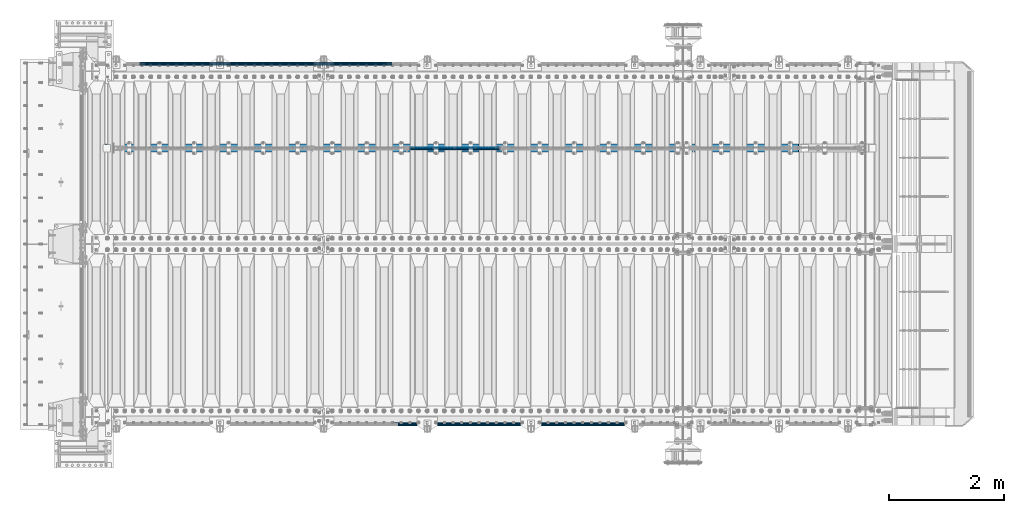
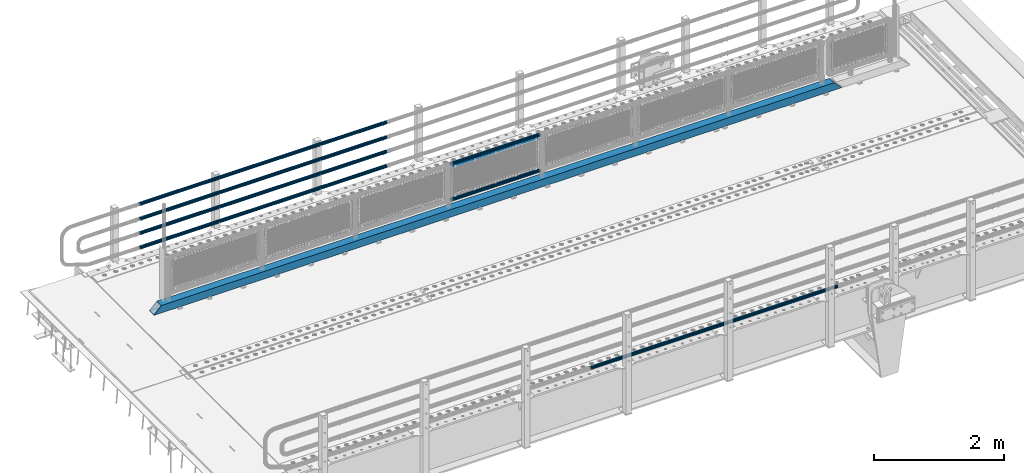
# One storey, part 92 of 193: 9 beams.
"""IFC2X3 building model written with IfcOpenShell, lengths in millimetres."""

from ifc_helpers import new_model, si_unit, frame, origin_with_axes, place, context, subcontext, project, spatial, faceted_brep, material, type_object, element, save


model = new_model("IFC2X3")

# Units and contexts
model_context = context("Model", 3, precision=1e-05, world=origin_with_axes())
body_context = subcontext(model_context, "Body", "Model", "MODEL_VIEW")
ifc_project = project(units=[si_unit("LENGTHUNIT", "METRE", prefix="MILLI"), si_unit("AREAUNIT", "SQUARE_METRE"), si_unit("VOLUMEUNIT", "CUBIC_METRE"), si_unit("MASSUNIT", "GRAM", prefix="KILO"), si_unit("TIMEUNIT", "SECOND"), si_unit("PLANEANGLEUNIT", "RADIAN"), si_unit("SOLIDANGLEUNIT", "STERADIAN"), si_unit("THERMODYNAMICTEMPERATUREUNIT", "DEGREE_CELSIUS"), si_unit("LUMINOUSINTENSITYUNIT", "LUMEN")], contexts=[model_context])

# Site, building, storey
site_placement = place(None, origin_with_axes())
site = spatial("IfcSite", under=ifc_project, at=site_placement, CompositionType="ELEMENT")
building_placement = place(site_placement, origin_with_axes())
building = spatial("IfcBuilding", under=site, at=building_placement, Name="Standard", CompositionType="ELEMENT")
storey_placement = place(building_placement, origin_with_axes())
storey = spatial("IfcBuildingStorey", under=building, at=storey_placement, Name="Undefined", CompositionType="ELEMENT", Elevation=0.0)

# Beams
ifc_material_1 = material()
beam_type_1 = type_object("IfcBeamType", PredefinedType="NOTDEFINED")
beam_1_placement = place(storey_placement, frame((-37116.0000000001, 30129.8500000001, 149.849999999748), z_axis=(0.0, 0.0, -1.0), x_axis=(-1.0, 0.0, 0.0)))
element("IfcBeam", 1, at=beam_1_placement, inside=storey, type_object=beam_type_1, material=ifc_material_1, context=body_context, shape_type="Brep", body=[
    faceted_brep([(0.0, -26.5499999999993, 0.0), (0.0, -24.5290015881765, 10.1602451292931), (4384.00249699992, -24.5290015881765, 10.1602451292931), (4384.00249699992, -26.5499999999993, 0.0), (0.0, -18.7736850405017, 18.7736850405028), (4384.00249699992, -18.7736850405017, 18.7736850405028), (0.0, -10.1602451292929, 24.5290015881747), (4384.00249699992, -10.1602451292929, 24.5290015881747), (0.0, 0.0, 26.55), (4384.00249699992, 0.0, 26.55), (0.0, 10.1602451292929, 24.5290015881747), (4384.00249699992, 10.1602451292929, 24.5290015881747), (0.0, 18.7736850405017, 18.7736850405028), (4384.00249699992, 18.7736850405017, 18.7736850405028), (0.0, 24.5290015881765, 10.1602451292931), (4384.00249699992, 24.5290015881765, 10.1602451292931), (0.0, 26.5499999999993, 0.0), (4384.00249699992, 26.5499999999993, 0.0), (0.0, 24.5290015881765, -10.1602451292931), (4384.00249699992, 24.5290015881765, -10.1602451292931), (0.0, 18.7736850405017, -18.7736850405028), (4384.00249699992, 18.7736850405017, -18.7736850405028), (0.0, 10.1602451292929, -24.5290015881747), (4384.00249699992, 10.1602451292929, -24.5290015881747), (0.0, 0.0, -26.55), (4384.00249699992, 0.0, -26.55), (0.0, -10.1602451292929, -24.5290015881747), (4384.00249699992, -10.1602451292929, -24.5290015881747), (0.0, -18.7736850405017, -18.7736850405028), (4384.00249699992, -18.7736850405017, -18.7736850405028), (0.0, -24.5290015881765, -10.1602451292931), (4384.00249699992, -24.5290015881765, -10.1602451292931), (0.0, -30.1500000000015, 0.0), (0.0, -27.8549679052157, -11.5379054858058), (4384.00249699992, -27.8549679052157, -11.5379054858075), (4384.00249699992, -30.1500000000015, 0.0), (0.0, -21.3192694527752, -21.3192694527752), (4384.00249699992, -21.3192694527752, -21.3192694527744), (0.0, -11.5379054858058, -27.8549679052157), (4384.00249699992, -11.5379054858058, -27.8549679052153), (0.0, 0.0, -30.1500000000015), (4384.00249699992, 0.0, -30.15), (0.0, 11.5379054858058, -27.8549679052157), (4384.00249699992, 11.5379054858058, -27.8549679052153), (0.0, 21.3192694527752, -21.3192694527752), (4384.00249699992, 21.3192694527752, -21.3192694527744), (0.0, 27.8549679052157, -11.5379054858058), (4384.00249699992, 27.8549679052157, -11.5379054858074), (0.0, 30.1500000000015, 0.0), (4384.00249699992, 30.1500000000015, 0.0), (0.0, 27.8549679052157, 11.5379054858058), (4384.00249699992, 27.8549679052157, 11.5379054858075), (0.0, 21.3192694527752, 21.3192694527752), (4384.00249699992, 21.3192694527752, 21.3192694527744), (0.0, 11.5379054858058, 27.8549679052157), (4384.00249699992, 11.5379054858058, 27.8549679052153), (0.0, 0.0, 30.1500000000015), (4384.00249699992, 0.0, 30.15), (0.0, -11.5379054858058, 27.8549679052157), (4384.00249699992, -11.5379054858058, 27.8549679052153), (0.0, -21.3192694527752, 21.3192694527752), (4384.00249699992, -21.3192694527752, 21.3192694527744), (0.0, -27.8549679052157, 11.5379054858058), (4384.00249699992, -27.8549679052157, 11.5379054858075)], [[[0, 1, 2, 3]], [[1, 4, 5, 2]], [[4, 6, 7, 5]], [[6, 8, 9, 7]], [[8, 10, 11, 9]], [[10, 12, 13, 11]], [[12, 14, 15, 13]], [[14, 16, 17, 15]], [[16, 18, 19, 17]], [[18, 20, 21, 19]], [[20, 22, 23, 21]], [[22, 24, 25, 23]], [[24, 26, 27, 25]], [[26, 28, 29, 27]], [[28, 30, 31, 29]], [[30, 0, 3, 31]], [[32, 33, 34, 35]], [[33, 36, 37, 34]], [[36, 38, 39, 37]], [[38, 40, 41, 39]], [[40, 42, 43, 41]], [[42, 44, 45, 43]], [[44, 46, 47, 45]], [[46, 48, 49, 47]], [[48, 50, 51, 49]], [[50, 52, 53, 51]], [[52, 54, 55, 53]], [[54, 56, 57, 55]], [[56, 58, 59, 57]], [[58, 60, 61, 59]], [[60, 62, 63, 61]], [[62, 32, 35, 63]], [[37, 39, 41, 43, 45, 47, 49, 51, 53, 55, 57, 59, 61, 63, 35, 34], [5, 7, 9, 11, 13, 15, 17, 19, 21, 23, 25, 27, 29, 31, 3, 2]], [[62, 60, 58, 56, 54, 52, 50, 48, 46, 44, 42, 40, 38, 36, 33, 32], [30, 28, 26, 24, 22, 20, 18, 16, 14, 12, 10, 8, 6, 4, 1, 0]]]),
])
beam_2_placement = place(storey_placement, frame((-37116.0000000001, 30129.8500000001, 420.149999999748), z_axis=(0.0, 0.0, -1.0), x_axis=(-1.0, 0.0, 0.0)))
element("IfcBeam", 2, at=beam_2_placement, inside=storey, type_object=beam_type_1, material=ifc_material_1, context=body_context, shape_type="Brep", body=[
    faceted_brep([(0.0, -26.5499999999993, 0.0), (0.0, -24.5290015881765, 10.1602451292931), (4384.00249699992, -24.5290015881765, 10.1602451292931), (4384.00249699992, -26.5499999999993, 0.0), (0.0, -18.7736850405017, 18.7736850405028), (4384.00249699992, -18.7736850405017, 18.7736850405028), (0.0, -10.1602451292929, 24.5290015881747), (4384.00249699992, -10.1602451292929, 24.5290015881747), (0.0, 0.0, 26.55), (4384.00249699992, 0.0, 26.55), (0.0, 10.1602451292929, 24.5290015881747), (4384.00249699992, 10.1602451292929, 24.5290015881747), (0.0, 18.7736850405017, 18.7736850405028), (4384.00249699992, 18.7736850405017, 18.7736850405028), (0.0, 24.5290015881765, 10.1602451292931), (4384.00249699992, 24.5290015881765, 10.1602451292931), (0.0, 26.5499999999993, 0.0), (4384.00249699992, 26.5499999999993, 0.0), (0.0, 24.5290015881765, -10.1602451292931), (4384.00249699992, 24.5290015881765, -10.1602451292931), (0.0, 18.7736850405017, -18.7736850405028), (4384.00249699992, 18.7736850405017, -18.7736850405028), (0.0, 10.1602451292929, -24.5290015881747), (4384.00249699992, 10.1602451292929, -24.5290015881747), (0.0, 0.0, -26.55), (4384.00249699992, 0.0, -26.55), (0.0, -10.1602451292929, -24.5290015881747), (4384.00249699992, -10.1602451292929, -24.5290015881747), (0.0, -18.7736850405017, -18.7736850405028), (4384.00249699992, -18.7736850405017, -18.7736850405028), (0.0, -24.5290015881765, -10.1602451292931), (4384.00249699992, -24.5290015881765, -10.1602451292931), (0.0, -30.1500000000015, 0.0), (0.0, -27.8549679052157, -11.5379054858058), (4384.00249699992, -27.8549679052157, -11.5379054858075), (4384.00249699992, -30.1500000000015, 0.0), (0.0, -21.3192694527752, -21.3192694527752), (4384.00249699992, -21.3192694527752, -21.3192694527744), (0.0, -11.5379054858058, -27.8549679052157), (4384.00249699992, -11.5379054858058, -27.8549679052153), (0.0, 0.0, -30.1500000000015), (4384.00249699992, 0.0, -30.15), (0.0, 11.5379054858058, -27.8549679052157), (4384.00249699992, 11.5379054858058, -27.8549679052153), (0.0, 21.3192694527752, -21.3192694527752), (4384.00249699992, 21.3192694527752, -21.3192694527744), (0.0, 27.8549679052157, -11.5379054858058), (4384.00249699992, 27.8549679052157, -11.5379054858074), (0.0, 30.1500000000015, 0.0), (4384.00249699992, 30.1500000000015, 0.0), (0.0, 27.8549679052157, 11.5379054858058), (4384.00249699992, 27.8549679052157, 11.5379054858075), (0.0, 21.3192694527752, 21.3192694527752), (4384.00249699992, 21.3192694527752, 21.3192694527744), (0.0, 11.5379054858058, 27.8549679052157), (4384.00249699992, 11.5379054858058, 27.8549679052153), (0.0, 0.0, 30.1500000000015), (4384.00249699992, 0.0, 30.15), (0.0, -11.5379054858058, 27.8549679052157), (4384.00249699992, -11.5379054858058, 27.8549679052153), (0.0, -21.3192694527752, 21.3192694527752), (4384.00249699992, -21.3192694527752, 21.3192694527744), (0.0, -27.8549679052157, 11.5379054858058), (4384.00249699992, -27.8549679052157, 11.5379054858075)], [[[0, 1, 2, 3]], [[1, 4, 5, 2]], [[4, 6, 7, 5]], [[6, 8, 9, 7]], [[8, 10, 11, 9]], [[10, 12, 13, 11]], [[12, 14, 15, 13]], [[14, 16, 17, 15]], [[16, 18, 19, 17]], [[18, 20, 21, 19]], [[20, 22, 23, 21]], [[22, 24, 25, 23]], [[24, 26, 27, 25]], [[26, 28, 29, 27]], [[28, 30, 31, 29]], [[30, 0, 3, 31]], [[32, 33, 34, 35]], [[33, 36, 37, 34]], [[36, 38, 39, 37]], [[38, 40, 41, 39]], [[40, 42, 43, 41]], [[42, 44, 45, 43]], [[44, 46, 47, 45]], [[46, 48, 49, 47]], [[48, 50, 51, 49]], [[50, 52, 53, 51]], [[52, 54, 55, 53]], [[54, 56, 57, 55]], [[56, 58, 59, 57]], [[58, 60, 61, 59]], [[60, 62, 63, 61]], [[62, 32, 35, 63]], [[37, 39, 41, 43, 45, 47, 49, 51, 53, 55, 57, 59, 61, 63, 35, 34], [5, 7, 9, 11, 13, 15, 17, 19, 21, 23, 25, 27, 29, 31, 3, 2]], [[62, 60, 58, 56, 54, 52, 50, 48, 46, 44, 42, 40, 38, 36, 33, 32], [30, 28, 26, 24, 22, 20, 18, 16, 14, 12, 10, 8, 6, 4, 1, 0]]]),
])
beam_3_placement = place(storey_placement, frame((-37116.0000000001, 30129.8500000001, 969.849999999748), z_axis=(0.0, 0.0, -1.0), x_axis=(-1.0, 0.0, 0.0)))
element("IfcBeam", 3, at=beam_3_placement, inside=storey, type_object=beam_type_1, material=ifc_material_1, context=body_context, shape_type="Brep", body=[
    faceted_brep([(0.0, -26.5499999999993, 0.0), (0.0, -24.5290015881765, 10.1602451292931), (4384.00249699992, -24.5290015881765, 10.1602451292931), (4384.00249699992, -26.5499999999993, 0.0), (0.0, -18.7736850405017, 18.7736850405028), (4384.00249699992, -18.7736850405017, 18.7736850405028), (0.0, -10.1602451292929, 24.5290015881747), (4384.00249699992, -10.1602451292929, 24.5290015881747), (0.0, 0.0, 26.55), (4384.00249699992, 0.0, 26.55), (0.0, 10.1602451292929, 24.5290015881747), (4384.00249699992, 10.1602451292929, 24.5290015881747), (0.0, 18.7736850405017, 18.7736850405028), (4384.00249699992, 18.7736850405017, 18.7736850405028), (0.0, 24.5290015881765, 10.1602451292931), (4384.00249699992, 24.5290015881765, 10.1602451292931), (0.0, 26.5499999999993, 0.0), (4384.00249699992, 26.5499999999993, 0.0), (0.0, 24.5290015881765, -10.1602451292931), (4384.00249699992, 24.5290015881765, -10.1602451292931), (0.0, 18.7736850405017, -18.7736850405028), (4384.00249699992, 18.7736850405017, -18.7736850405028), (0.0, 10.1602451292929, -24.5290015881747), (4384.00249699992, 10.1602451292929, -24.5290015881747), (0.0, 0.0, -26.55), (4384.00249699992, 0.0, -26.55), (0.0, -10.1602451292929, -24.5290015881747), (4384.00249699992, -10.1602451292929, -24.5290015881747), (0.0, -18.7736850405017, -18.7736850405028), (4384.00249699992, -18.7736850405017, -18.7736850405028), (0.0, -24.5290015881765, -10.1602451292931), (4384.00249699992, -24.5290015881765, -10.1602451292931), (0.0, -30.1500000000015, 0.0), (0.0, -27.8549679052157, -11.5379054858058), (4384.00249699992, -27.8549679052157, -11.5379054858075), (4384.00249699992, -30.1500000000015, 0.0), (0.0, -21.3192694527752, -21.3192694527752), (4384.00249699992, -21.3192694527752, -21.3192694527744), (0.0, -11.5379054858058, -27.8549679052157), (4384.00249699992, -11.5379054858058, -27.8549679052153), (0.0, 0.0, -30.1500000000015), (4384.00249699992, 0.0, -30.15), (0.0, 11.5379054858058, -27.8549679052157), (4384.00249699992, 11.5379054858058, -27.8549679052153), (0.0, 21.3192694527752, -21.3192694527752), (4384.00249699992, 21.3192694527752, -21.3192694527744), (0.0, 27.8549679052157, -11.5379054858058), (4384.00249699992, 27.8549679052157, -11.5379054858074), (0.0, 30.1500000000015, 0.0), (4384.00249699992, 30.1500000000015, 0.0), (0.0, 27.8549679052157, 11.5379054858058), (4384.00249699992, 27.8549679052157, 11.5379054858075), (0.0, 21.3192694527752, 21.3192694527752), (4384.00249699992, 21.3192694527752, 21.3192694527744), (0.0, 11.5379054858058, 27.8549679052157), (4384.00249699992, 11.5379054858058, 27.8549679052153), (0.0, 0.0, 30.1500000000015), (4384.00249699992, 0.0, 30.15), (0.0, -11.5379054858058, 27.8549679052157), (4384.00249699992, -11.5379054858058, 27.8549679052153), (0.0, -21.3192694527752, 21.3192694527752), (4384.00249699992, -21.3192694527752, 21.3192694527744), (0.0, -27.8549679052157, 11.5379054858058), (4384.00249699992, -27.8549679052157, 11.5379054858075)], [[[0, 1, 2, 3]], [[1, 4, 5, 2]], [[4, 6, 7, 5]], [[6, 8, 9, 7]], [[8, 10, 11, 9]], [[10, 12, 13, 11]], [[12, 14, 15, 13]], [[14, 16, 17, 15]], [[16, 18, 19, 17]], [[18, 20, 21, 19]], [[20, 22, 23, 21]], [[22, 24, 25, 23]], [[24, 26, 27, 25]], [[26, 28, 29, 27]], [[28, 30, 31, 29]], [[30, 0, 3, 31]], [[32, 33, 34, 35]], [[33, 36, 37, 34]], [[36, 38, 39, 37]], [[38, 40, 41, 39]], [[40, 42, 43, 41]], [[42, 44, 45, 43]], [[44, 46, 47, 45]], [[46, 48, 49, 47]], [[48, 50, 51, 49]], [[50, 52, 53, 51]], [[52, 54, 55, 53]], [[54, 56, 57, 55]], [[56, 58, 59, 57]], [[58, 60, 61, 59]], [[60, 62, 63, 61]], [[62, 32, 35, 63]], [[37, 39, 41, 43, 45, 47, 49, 51, 53, 55, 57, 59, 61, 63, 35, 34], [5, 7, 9, 11, 13, 15, 17, 19, 21, 23, 25, 27, 29, 31, 3, 2]], [[62, 60, 58, 56, 54, 52, 50, 48, 46, 44, 42, 40, 38, 36, 33, 32], [30, 28, 26, 24, 22, 20, 18, 16, 14, 12, 10, 8, 6, 4, 1, 0]]]),
])
beam_4_placement = place(storey_placement, frame((-37116.0000000001, 30129.8500000001, 689.849999999748), z_axis=(0.0, 0.0, -1.0), x_axis=(-1.0, 0.0, 0.0)))
element("IfcBeam", 4, at=beam_4_placement, inside=storey, type_object=beam_type_1, material=ifc_material_1, context=body_context, shape_type="Brep", body=[
    faceted_brep([(0.0, -26.5499999999993, 0.0), (0.0, -24.5290015881765, 10.1602451292931), (4384.00249699992, -24.5290015881765, 10.1602451292931), (4384.00249699992, -26.5499999999993, 0.0), (0.0, -18.7736850405017, 18.7736850405028), (4384.00249699992, -18.7736850405017, 18.7736850405028), (0.0, -10.1602451292929, 24.5290015881747), (4384.00249699992, -10.1602451292929, 24.5290015881747), (0.0, 0.0, 26.55), (4384.00249699992, 0.0, 26.55), (0.0, 10.1602451292929, 24.5290015881747), (4384.00249699992, 10.1602451292929, 24.5290015881747), (0.0, 18.7736850405017, 18.7736850405028), (4384.00249699992, 18.7736850405017, 18.7736850405028), (0.0, 24.5290015881765, 10.1602451292931), (4384.00249699992, 24.5290015881765, 10.1602451292931), (0.0, 26.5499999999993, 0.0), (4384.00249699992, 26.5499999999993, 0.0), (0.0, 24.5290015881765, -10.1602451292931), (4384.00249699992, 24.5290015881765, -10.1602451292931), (0.0, 18.7736850405017, -18.7736850405028), (4384.00249699992, 18.7736850405017, -18.7736850405028), (0.0, 10.1602451292929, -24.5290015881747), (4384.00249699992, 10.1602451292929, -24.5290015881747), (0.0, 0.0, -26.55), (4384.00249699992, 0.0, -26.55), (0.0, -10.1602451292929, -24.5290015881747), (4384.00249699992, -10.1602451292929, -24.5290015881747), (0.0, -18.7736850405017, -18.7736850405028), (4384.00249699992, -18.7736850405017, -18.7736850405028), (0.0, -24.5290015881765, -10.1602451292931), (4384.00249699992, -24.5290015881765, -10.1602451292931), (0.0, -30.1500000000015, 0.0), (0.0, -27.8549679052157, -11.5379054858058), (4384.00249699992, -27.8549679052157, -11.5379054858075), (4384.00249699992, -30.1500000000015, 0.0), (0.0, -21.3192694527752, -21.3192694527752), (4384.00249699992, -21.3192694527752, -21.3192694527744), (0.0, -11.5379054858058, -27.8549679052157), (4384.00249699992, -11.5379054858058, -27.8549679052153), (0.0, 0.0, -30.1500000000015), (4384.00249699992, 0.0, -30.15), (0.0, 11.5379054858058, -27.8549679052157), (4384.00249699992, 11.5379054858058, -27.8549679052153), (0.0, 21.3192694527752, -21.3192694527752), (4384.00249699992, 21.3192694527752, -21.3192694527744), (0.0, 27.8549679052157, -11.5379054858058), (4384.00249699992, 27.8549679052157, -11.5379054858074), (0.0, 30.1500000000015, 0.0), (4384.00249699992, 30.1500000000015, 0.0), (0.0, 27.8549679052157, 11.5379054858058), (4384.00249699992, 27.8549679052157, 11.5379054858075), (0.0, 21.3192694527752, 21.3192694527752), (4384.00249699992, 21.3192694527752, 21.3192694527744), (0.0, 11.5379054858058, 27.8549679052157), (4384.00249699992, 11.5379054858058, 27.8549679052153), (0.0, 0.0, 30.1500000000015), (4384.00249699992, 0.0, 30.15), (0.0, -11.5379054858058, 27.8549679052157), (4384.00249699992, -11.5379054858058, 27.8549679052153), (0.0, -21.3192694527752, 21.3192694527752), (4384.00249699992, -21.3192694527752, 21.3192694527744), (0.0, -27.8549679052157, 11.5379054858058), (4384.00249699992, -27.8549679052157, 11.5379054858075)], [[[0, 1, 2, 3]], [[1, 4, 5, 2]], [[4, 6, 7, 5]], [[6, 8, 9, 7]], [[8, 10, 11, 9]], [[10, 12, 13, 11]], [[12, 14, 15, 13]], [[14, 16, 17, 15]], [[16, 18, 19, 17]], [[18, 20, 21, 19]], [[20, 22, 23, 21]], [[22, 24, 25, 23]], [[24, 26, 27, 25]], [[26, 28, 29, 27]], [[28, 30, 31, 29]], [[30, 0, 3, 31]], [[32, 33, 34, 35]], [[33, 36, 37, 34]], [[36, 38, 39, 37]], [[38, 40, 41, 39]], [[40, 42, 43, 41]], [[42, 44, 45, 43]], [[44, 46, 47, 45]], [[46, 48, 49, 47]], [[48, 50, 51, 49]], [[50, 52, 53, 51]], [[52, 54, 55, 53]], [[54, 56, 57, 55]], [[56, 58, 59, 57]], [[58, 60, 61, 59]], [[60, 62, 63, 61]], [[62, 32, 35, 63]], [[37, 39, 41, 43, 45, 47, 49, 51, 53, 55, 57, 59, 61, 63, 35, 34], [5, 7, 9, 11, 13, 15, 17, 19, 21, 23, 25, 27, 29, 31, 3, 2]], [[62, 60, 58, 56, 54, 52, 50, 48, 46, 44, 42, 40, 38, 36, 33, 32], [30, 28, 26, 24, 22, 20, 18, 16, 14, 12, 10, 8, 6, 4, 1, 0]]]),
])
beam_5_placement = place(storey_placement, frame((-32722.0000000001, 23870.1500000001, 149.849999999748), z_axis=(0.0, 0.0, -1.0), x_axis=(-1.0, 0.0, 0.0)))
element("IfcBeam", 5, at=beam_5_placement, inside=storey, type_object=beam_type_1, material=ifc_material_1, context=body_context, shape_type="Brep", body=[
    faceted_brep([(0.0, -26.5499999999993, 0.0), (0.0, -24.5290015881765, 10.1602451292931), (4384.00249699992, -24.5290015881765, 10.1602451292931), (4384.00249699992, -26.5499999999993, 0.0), (0.0, -18.7736850405017, 18.7736850405028), (4384.00249699992, -18.7736850405017, 18.7736850405028), (0.0, -10.1602451292929, 24.5290015881747), (4384.00249699992, -10.1602451292929, 24.5290015881747), (0.0, 0.0, 26.55), (4384.00249699992, 0.0, 26.55), (0.0, 10.1602451292929, 24.5290015881747), (4384.00249699992, 10.1602451292929, 24.5290015881747), (0.0, 18.7736850405017, 18.7736850405028), (4384.00249699992, 18.7736850405017, 18.7736850405028), (0.0, 24.5290015881765, 10.1602451292931), (4384.00249699992, 24.5290015881765, 10.1602451292931), (0.0, 26.5499999999993, 0.0), (4384.00249699992, 26.5499999999993, 0.0), (0.0, 24.5290015881765, -10.1602451292931), (4384.00249699992, 24.5290015881765, -10.1602451292931), (0.0, 18.7736850405017, -18.7736850405028), (4384.00249699992, 18.7736850405017, -18.7736850405028), (0.0, 10.1602451292929, -24.5290015881747), (4384.00249699992, 10.1602451292929, -24.5290015881747), (0.0, 0.0, -26.55), (4384.00249699992, 0.0, -26.55), (0.0, -10.1602451292929, -24.5290015881747), (4384.00249699992, -10.1602451292929, -24.5290015881747), (0.0, -18.7736850405017, -18.7736850405028), (4384.00249699992, -18.7736850405017, -18.7736850405028), (0.0, -24.5290015881765, -10.1602451292931), (4384.00249699992, -24.5290015881765, -10.1602451292931), (0.0, -30.1500000000015, 0.0), (0.0, -27.8549679052157, -11.5379054858058), (4384.00249699992, -27.8549679052157, -11.5379054858075), (4384.00249699992, -30.1500000000015, 0.0), (0.0, -21.3192694527752, -21.3192694527752), (4384.00249699992, -21.3192694527752, -21.3192694527744), (0.0, -11.5379054858058, -27.8549679052157), (4384.00249699992, -11.5379054858058, -27.8549679052153), (0.0, 0.0, -30.1500000000015), (4384.00249699992, 0.0, -30.15), (0.0, 11.5379054858058, -27.8549679052157), (4384.00249699992, 11.5379054858058, -27.8549679052153), (0.0, 21.3192694527752, -21.3192694527752), (4384.00249699992, 21.3192694527752, -21.3192694527744), (0.0, 27.8549679052157, -11.5379054858058), (4384.00249699992, 27.8549679052157, -11.5379054858074), (0.0, 30.1500000000015, 0.0), (4384.00249699992, 30.1500000000015, 0.0), (0.0, 27.8549679052157, 11.5379054858058), (4384.00249699992, 27.8549679052157, 11.5379054858075), (0.0, 21.3192694527752, 21.3192694527752), (4384.00249699992, 21.3192694527752, 21.3192694527744), (0.0, 11.5379054858058, 27.8549679052157), (4384.00249699992, 11.5379054858058, 27.8549679052153), (0.0, 0.0, 30.1500000000015), (4384.00249699992, 0.0, 30.15), (0.0, -11.5379054858058, 27.8549679052157), (4384.00249699992, -11.5379054858058, 27.8549679052153), (0.0, -21.3192694527752, 21.3192694527752), (4384.00249699992, -21.3192694527752, 21.3192694527744), (0.0, -27.8549679052157, 11.5379054858058), (4384.00249699992, -27.8549679052157, 11.5379054858075)], [[[0, 1, 2, 3]], [[1, 4, 5, 2]], [[4, 6, 7, 5]], [[6, 8, 9, 7]], [[8, 10, 11, 9]], [[10, 12, 13, 11]], [[12, 14, 15, 13]], [[14, 16, 17, 15]], [[16, 18, 19, 17]], [[18, 20, 21, 19]], [[20, 22, 23, 21]], [[22, 24, 25, 23]], [[24, 26, 27, 25]], [[26, 28, 29, 27]], [[28, 30, 31, 29]], [[30, 0, 3, 31]], [[32, 33, 34, 35]], [[33, 36, 37, 34]], [[36, 38, 39, 37]], [[38, 40, 41, 39]], [[40, 42, 43, 41]], [[42, 44, 45, 43]], [[44, 46, 47, 45]], [[46, 48, 49, 47]], [[48, 50, 51, 49]], [[50, 52, 53, 51]], [[52, 54, 55, 53]], [[54, 56, 57, 55]], [[56, 58, 59, 57]], [[58, 60, 61, 59]], [[60, 62, 63, 61]], [[62, 32, 35, 63]], [[37, 39, 41, 43, 45, 47, 49, 51, 53, 55, 57, 59, 61, 63, 35, 34], [5, 7, 9, 11, 13, 15, 17, 19, 21, 23, 25, 27, 29, 31, 3, 2]], [[62, 60, 58, 56, 54, 52, 50, 48, 46, 44, 42, 40, 38, 36, 33, 32], [30, 28, 26, 24, 22, 20, 18, 16, 14, 12, 10, 8, 6, 4, 1, 0]]]),
])
ifc_material_2 = material(Name="Misc_Undefined")
beam_type_2 = type_object("IfcBeamType", Name="D3", PredefinedType="NOTDEFINED")
beam_6_placement = place(storey_placement, frame((-36775.0, 28670.5, 913.02), z_axis=(0.0, 0.0, 1.0), x_axis=(1.0, 0.0, 0.0)))
element("IfcBeam", 6, at=beam_6_placement, inside=storey, type_object=beam_type_2, material=ifc_material_2, ObjectType="D3", context=body_context, shape_type="Brep", body=[
    faceted_brep([(0.0, -1.49999999999636, 3.63797880709171e-12), (0.0, -0.75, -1.29903810567669), (1498.0, -0.75, -1.29903810567669), (1498.0, -1.5, 0.0), (0.0, 0.75, -1.29903810567669), (1498.0, 0.75, -1.29903810567663), (0.0, 1.50000000000364, 7.27595761418343e-12), (1498.0, 1.5, 0.0), (0.0, 0.75, 1.29903810567669), (1498.0, 0.75, 1.29903810567669), (0.0, -0.75, 1.29903810567669), (1498.0, -0.75, 1.29903810567669)], [[[0, 1, 2, 3]], [[1, 4, 5, 2]], [[4, 6, 7, 5]], [[6, 8, 9, 7]], [[8, 10, 11, 9]], [[10, 0, 3, 11]], [[5, 7, 9, 11, 3, 2]], [[10, 8, 6, 4, 1, 0]]]),
])
beam_type_3 = type_object("IfcBeamType", PredefinedType="NOTDEFINED")
beam_7_placement = place(storey_placement, frame((-36820.15, 28664.5, 969.85), z_axis=(0.0, 0.0, 1.0), x_axis=(1.0, 0.0, 0.0)))
element("IfcBeam", 7, at=beam_7_placement, inside=storey, type_object=beam_type_3, material=ifc_material_1, context=body_context, shape_type="Brep", body=[
    faceted_brep([(0.0, -25.3499999999985, 0.0), (0.0, -23.4203461491597, 9.70102501045403), (1588.0, -23.4203461491597, 9.70102501045506), (1588.0, -25.3499999999985, 0.0), (0.0, -17.9251569030785, 17.9251569030785), (1588.0, -17.9251569030785, 17.925156903079), (0.0, -9.70102501045403, 23.4203461491597), (1588.0, -9.70102501045403, 23.4203461491611), (0.0, 0.0, 25.3499999999985), (1588.0, 0.0, 25.35), (0.0, 9.70102501045403, 23.4203461491597), (1588.0, 9.70102501045403, 23.4203461491611), (0.0, 17.9251569030785, 17.9251569030785), (1588.0, 17.9251569030785, 17.925156903079), (0.0, 23.4203461491597, 9.70102501045403), (1588.0, 23.4203461491597, 9.70102501045506), (0.0, 25.3499999999985, 0.0), (1588.0, 25.3499999999985, 0.0), (0.0, 23.4203461491597, -9.70102501045403), (1588.0, 23.4203461491597, -9.70102501045506), (0.0, 17.9251569030785, -17.9251569030785), (1588.0, 17.9251569030785, -17.925156903079), (0.0, 9.70102501045403, -23.4203461491597), (1588.0, 9.70102501045403, -23.4203461491611), (0.0, 0.0, -25.3499999999985), (1588.0, 0.0, -25.35), (0.0, -9.70102501045403, -23.4203461491597), (1588.0, -9.70102501045403, -23.4203461491611), (0.0, -17.9251569030785, -17.9251569030785), (1588.0, -17.9251569030785, -17.925156903079), (0.0, -23.4203461491597, -9.70102501045403), (1588.0, -23.4203461491597, -9.70102501045506), (0.0, -30.1500000000015, 0.0), (0.0, -27.8549679052157, -11.5379054858058), (1588.0, -27.8549679052157, -11.5379054858075), (1588.0, -30.1500000000015, 0.0), (0.0, -21.3192694527752, -21.3192694527752), (1588.0, -21.3192694527752, -21.3192694527744), (0.0, -11.5379054858058, -27.8549679052157), (1588.0, -11.5379054858058, -27.8549679052153), (0.0, 0.0, -30.1500000000015), (1588.0, 0.0, -30.15), (0.0, 11.5379054858058, -27.8549679052157), (1588.0, 11.5379054858058, -27.8549679052153), (0.0, 21.3192694527752, -21.3192694527752), (1588.0, 21.3192694527752, -21.3192694527744), (0.0, 27.8549679052157, -11.5379054858058), (1588.0, 27.8549679052157, -11.5379054858074), (0.0, 30.1500000000015, 0.0), (1588.0, 30.1500000000015, 0.0), (0.0, 27.8549679052157, 11.5379054858058), (1588.0, 27.8549679052157, 11.5379054858074), (0.0, 21.3192694527752, 21.3192694527752), (1588.0, 21.3192694527752, 21.3192694527744), (0.0, 11.5379054858058, 27.8549679052157), (1588.0, 11.5379054858058, 27.8549679052153), (0.0, 0.0, 30.1500000000015), (1588.0, 0.0, 30.15), (0.0, -11.5379054858058, 27.8549679052157), (1588.0, -11.5379054858058, 27.8549679052153), (0.0, -21.3192694527752, 21.3192694527752), (1588.0, -21.3192694527752, 21.3192694527744), (0.0, -27.8549679052157, 11.5379054858058), (1588.0, -27.8549679052157, 11.5379054858074)], [[[0, 1, 2, 3]], [[1, 4, 5, 2]], [[4, 6, 7, 5]], [[6, 8, 9, 7]], [[8, 10, 11, 9]], [[10, 12, 13, 11]], [[12, 14, 15, 13]], [[14, 16, 17, 15]], [[16, 18, 19, 17]], [[18, 20, 21, 19]], [[20, 22, 23, 21]], [[22, 24, 25, 23]], [[24, 26, 27, 25]], [[26, 28, 29, 27]], [[28, 30, 31, 29]], [[30, 0, 3, 31]], [[32, 33, 34, 35]], [[33, 36, 37, 34]], [[36, 38, 39, 37]], [[38, 40, 41, 39]], [[40, 42, 43, 41]], [[42, 44, 45, 43]], [[44, 46, 47, 45]], [[46, 48, 49, 47]], [[48, 50, 51, 49]], [[50, 52, 53, 51]], [[52, 54, 55, 53]], [[54, 56, 57, 55]], [[56, 58, 59, 57]], [[58, 60, 61, 59]], [[60, 62, 63, 61]], [[62, 32, 35, 63]], [[37, 39, 41, 43, 45, 47, 49, 51, 53, 55, 57, 59, 61, 63, 35, 34], [5, 7, 9, 11, 13, 15, 17, 19, 21, 23, 25, 27, 29, 31, 3, 2]], [[62, 60, 58, 56, 54, 52, 50, 48, 46, 44, 42, 40, 38, 36, 33, 32], [30, 28, 26, 24, 22, 20, 18, 16, 14, 12, 10, 8, 6, 4, 1, 0]]]),
])
beam_8_placement = place(storey_placement, frame((-36820.15, 28664.5, 298.170000000002), z_axis=(0.0, 0.0, 1.0), x_axis=(1.0, 0.0, 0.0)))
element("IfcBeam", 8, at=beam_8_placement, inside=storey, type_object=beam_type_3, material=ifc_material_1, context=body_context, shape_type="Brep", body=[
    faceted_brep([(0.0, -25.3499999999985, 0.0), (0.0, -23.4203461491597, 9.70102501045403), (1588.0, -23.4203461491597, 9.70102501045506), (1588.0, -25.3499999999985, 0.0), (0.0, -17.9251569030785, 17.9251569030785), (1588.0, -17.9251569030785, 17.925156903079), (0.0, -9.70102501045403, 23.4203461491597), (1588.0, -9.70102501045403, 23.4203461491611), (0.0, 0.0, 25.3499999999985), (1588.0, 0.0, 25.35), (0.0, 9.70102501045403, 23.4203461491597), (1588.0, 9.70102501045403, 23.4203461491611), (0.0, 17.9251569030785, 17.9251569030785), (1588.0, 17.9251569030785, 17.925156903079), (0.0, 23.4203461491597, 9.70102501045403), (1588.0, 23.4203461491597, 9.70102501045506), (0.0, 25.3499999999985, 0.0), (1588.0, 25.3499999999985, 0.0), (0.0, 23.4203461491597, -9.70102501045403), (1588.0, 23.4203461491597, -9.70102501045506), (0.0, 17.9251569030785, -17.9251569030785), (1588.0, 17.9251569030785, -17.925156903079), (0.0, 9.70102501045403, -23.4203461491597), (1588.0, 9.70102501045403, -23.4203461491611), (0.0, 0.0, -25.3499999999985), (1588.0, 0.0, -25.35), (0.0, -9.70102501045403, -23.4203461491597), (1588.0, -9.70102501045403, -23.4203461491611), (0.0, -17.9251569030785, -17.9251569030785), (1588.0, -17.9251569030785, -17.925156903079), (0.0, -23.4203461491597, -9.70102501045403), (1588.0, -23.4203461491597, -9.70102501045506), (0.0, -30.1500000000015, 0.0), (0.0, -27.8549679052157, -11.5379054858058), (1588.0, -27.8549679052157, -11.5379054858075), (1588.0, -30.1500000000015, 0.0), (0.0, -21.3192694527752, -21.3192694527752), (1588.0, -21.3192694527752, -21.3192694527744), (0.0, -11.5379054858058, -27.8549679052157), (1588.0, -11.5379054858058, -27.8549679052153), (0.0, 0.0, -30.1500000000015), (1588.0, 0.0, -30.15), (0.0, 11.5379054858058, -27.8549679052157), (1588.0, 11.5379054858058, -27.8549679052153), (0.0, 21.3192694527752, -21.3192694527752), (1588.0, 21.3192694527752, -21.3192694527744), (0.0, 27.8549679052157, -11.5379054858058), (1588.0, 27.8549679052157, -11.5379054858074), (0.0, 30.1500000000015, 0.0), (1588.0, 30.1500000000015, 0.0), (0.0, 27.8549679052157, 11.5379054858058), (1588.0, 27.8549679052157, 11.5379054858074), (0.0, 21.3192694527752, 21.3192694527752), (1588.0, 21.3192694527752, 21.3192694527744), (0.0, 11.5379054858058, 27.8549679052157), (1588.0, 11.5379054858058, 27.8549679052153), (0.0, 0.0, 30.1500000000015), (1588.0, 0.0, 30.15), (0.0, -11.5379054858058, 27.8549679052157), (1588.0, -11.5379054858058, 27.8549679052153), (0.0, -21.3192694527752, 21.3192694527752), (1588.0, -21.3192694527752, 21.3192694527744), (0.0, -27.8549679052157, 11.5379054858058), (1588.0, -27.8549679052157, 11.5379054858074)], [[[0, 1, 2, 3]], [[1, 4, 5, 2]], [[4, 6, 7, 5]], [[6, 8, 9, 7]], [[8, 10, 11, 9]], [[10, 12, 13, 11]], [[12, 14, 15, 13]], [[14, 16, 17, 15]], [[16, 18, 19, 17]], [[18, 20, 21, 19]], [[20, 22, 23, 21]], [[22, 24, 25, 23]], [[24, 26, 27, 25]], [[26, 28, 29, 27]], [[28, 30, 31, 29]], [[30, 0, 3, 31]], [[32, 33, 34, 35]], [[33, 36, 37, 34]], [[36, 38, 39, 37]], [[38, 40, 41, 39]], [[40, 42, 43, 41]], [[42, 44, 45, 43]], [[44, 46, 47, 45]], [[46, 48, 49, 47]], [[48, 50, 51, 49]], [[50, 52, 53, 51]], [[52, 54, 55, 53]], [[54, 56, 57, 55]], [[56, 58, 59, 57]], [[58, 60, 61, 59]], [[60, 62, 63, 61]], [[62, 32, 35, 63]], [[37, 39, 41, 43, 45, 47, 49, 51, 53, 55, 57, 59, 61, 63, 35, 34], [5, 7, 9, 11, 13, 15, 17, 19, 21, 23, 25, 27, 29, 31, 3, 2]], [[62, 60, 58, 56, 54, 52, 50, 48, 46, 44, 42, 40, 38, 36, 33, 32], [30, 28, 26, 24, 22, 20, 18, 16, 14, 12, 10, 8, 6, 4, 1, 0]]]),
])
beam_type_4 = type_object("IfcBeamType", PredefinedType="NOTDEFINED")
beam_9_placement = place(storey_placement, frame((-42125.0, 28664.5, 98.0199999999977), z_axis=(0.0, 0.0, 1.0), x_axis=(1.0, 0.0, 0.0)))
element("IfcBeam", 9, at=beam_9_placement, inside=storey, type_object=beam_type_4, material=ifc_material_1, context=body_context, shape_type="Brep", body=[
    faceted_brep([(0.0, -70.0, -70.0), (0.0, 70.0, -70.0), (12202.0, 70.0, -70.0), (12202.0, -70.0, -70.0), (12071.8884698478, -70.0, 70.0), (12071.8884698478, 70.0, 70.0), (130.111530936141, 70.0, 70.0), (130.111528976144, -70.0, 70.0), (12202.0, -70.0, -60.0079600980746), (0.0, -70.0, -60.0079591069104), (12081.8964362873, -60.0, 60.0), (12202.0, -60.0, -60.0), (0.0, -60.0, -60.0), (120.103562690856, -60.0, 60.0), (12081.8964362873, 60.0, 60.0), (120.103564370853, 60.0, 60.0), (12202.0, 60.0, -60.0), (0.0, 60.0, -60.0), (12202.0, 70.0, -60.0079600980746), (0.0, 70.0, -60.007961065347)], [[[0, 1, 2, 3]], [[4, 5, 6, 7]], [[0, 3, 8, 4, 7, 9]], [[10, 11, 12, 13]], [[14, 10, 13, 15]], [[16, 14, 15, 17]], [[4, 8, 11, 10, 14, 16, 18, 5]], [[11, 8, 3, 2, 18, 16]], [[17, 12, 11, 16]], [[1, 0, 9, 12, 17, 19]], [[5, 18, 2, 1, 19, 6]], [[17, 15, 13, 12, 9, 7, 6, 19]]]),
])

save(model, "model.ifc")
